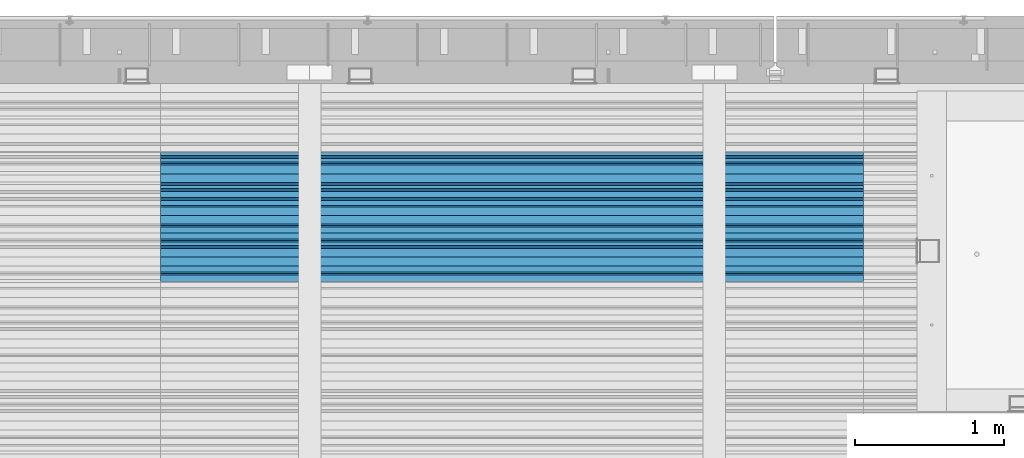
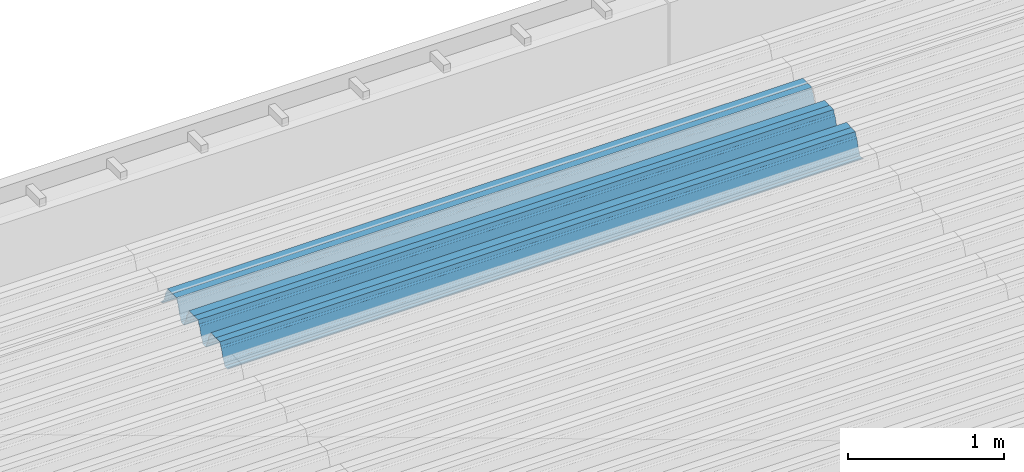
# One storey, part 34 of 153: 1 beam, 1 element without a shape of its own.
"""IFC2X3 building model written with IfcOpenShell, lengths in millimetres."""

from ifc_helpers import new_model, si_unit, frame, origin_with_axes, place, context, subcontext, project, spatial, faceted_brep, material, type_object, element, aggregate, save


model = new_model("IFC2X3")

# Units and contexts
model_context = context("Model", 3, precision=1e-05, world=origin_with_axes())
body_context = subcontext(model_context, "Body", "Model", "MODEL_VIEW")
ifc_project = project(units=[si_unit("LENGTHUNIT", "METRE", prefix="MILLI"), si_unit("AREAUNIT", "SQUARE_METRE"), si_unit("VOLUMEUNIT", "CUBIC_METRE"), si_unit("MASSUNIT", "GRAM", prefix="KILO"), si_unit("TIMEUNIT", "SECOND"), si_unit("PLANEANGLEUNIT", "RADIAN"), si_unit("SOLIDANGLEUNIT", "STERADIAN"), si_unit("THERMODYNAMICTEMPERATUREUNIT", "DEGREE_CELSIUS"), si_unit("LUMINOUSINTENSITYUNIT", "LUMEN")], contexts=[model_context])

# Site, building, storey
site_placement = place(None, origin_with_axes())
site = spatial("IfcSite", under=ifc_project, at=site_placement, CompositionType="ELEMENT")
building_placement = place(site_placement, origin_with_axes())
building = spatial("IfcBuilding", under=site, at=building_placement, CompositionType="ELEMENT")
storey_placement = place(building_placement, origin_with_axes())
storey = spatial("IfcBuildingStorey", under=building, at=storey_placement, Name="8", CompositionType="ELEMENT", Elevation=0.0)

# Assembly, beam
assembly_placement = place(storey_placement, origin_with_axes())
assembly = element("IfcElementAssembly", 1, at=assembly_placement, inside=storey, Name="Steel Assembly", AssemblyPlace="NOTDEFINED", PredefinedType="RIGID_FRAME")
ifc_material = material(Name="STEEL/S355J2")
beam_type = type_object("IfcBeamType", Name="W", PredefinedType="NOTDEFINED")
beam_placement = place(assembly_placement, frame((17251.9999999917, 19534.8848733029, 105801.771450345), z_axis=(0.0, -0.0124990270013869, 0.999921884110963), x_axis=(-1.0, 3.00000001838171e-08, 0.0)))
beam = element("IfcBeam", 2, at=beam_placement, type_object=beam_type, material=ifc_material, ObjectType="W", context=body_context, shape_type="Brep", body=[
    faceted_brep([(0.0, -412.839996337891, -77.0100021362159), (0.0, -409.160003662109, -77.0100021362014), (4717.0, -409.160003662109, -77.0100021362159), (4717.0, -412.839996337891, -77.0100021362159), (0.0, -408.070007324222, -73.4800033569045), (4717.0, -408.070007324222, -73.480003356919), (0.0, -400.339996337894, -48.0600013732619), (4717.0, -400.339996337894, -48.0600013732765), (0.0, -399.459991455082, -46.5600013732619), (4717.0, -399.459991455078, -46.5600013732765), (0.0, -390.329986572269, -36.5499992370314), (4717.0, -390.329986572266, -36.549999237046), (0.0, -389.19000244141, -34.6300010680861), (4717.0, -389.190002441403, -34.6300010681007), (0.0, -367.820007324222, 35.3400001526024), (4717.0, -367.820007324219, 35.3400001525879), (0.0, -366.989990234379, 36.8499984741502), (4717.0, -366.989990234375, 36.8499984741356), (0.0, -357.809997558597, 46.8600006103807), (4717.0, -357.809997558594, 46.8600006103661), (0.0, -356.720001220707, 48.7700004577782), (4717.0, -356.720001220703, 48.7700004577782), (0.0, -349.309997558594, 73.1500015258935), (4717.0, -349.309997558594, 73.1500015258935), (0.0, -347.850006103516, 75.2300033569481), (4717.0, -347.850006103516, 75.2300033569481), (0.0, -345.470001220707, 76.010002136245), (4717.0, -345.470001220703, 76.0100021362305), (0.0, -305.480010986332, 76.010002136245), (4717.0, -305.480010986324, 76.0100021362305), (0.0, -304.279998779301, 75.8000030517578), (4717.0, -304.279998779301, 75.8000030517724), (0.0, -291.679992675785, 71.6999969482567), (4717.0, -291.679992675785, 71.6999969482567), (0.0, -290.179992675789, 71.2300033569481), (4717.0, -290.179992675781, 71.2300033569481), (0.0, -288.720001220707, 71.6999969482567), (4717.0, -288.720001220703, 71.6999969482422), (0.0, -276.119995117191, 75.8000030517869), (4717.0, -276.119995117188, 75.8000030517724), (0.0, -274.929992675785, 76.010002136245), (4717.0, -274.929992675785, 76.010002136245), (0.0, -234.94000244141, 76.010002136245), (4717.0, -234.94000244141, 76.010002136245), (0.0, -232.550003051758, 75.2300033569627), (4717.0, -232.550003051758, 75.2300033569481), (0.0, -231.100006103519, 73.1500015258935), (4717.0, -231.100006103516, 73.1500015258789), (0.0, -223.679992675785, 48.7700004577782), (4717.0, -223.679992675781, 48.7700004577782), (0.0, -222.589996337894, 46.8600006103661), (4717.0, -222.589996337891, 46.8600006103516), (0.0, -213.410003662113, 36.8499984741502), (4717.0, -213.410003662109, 36.8499984741356), (0.0, -212.529998779301, 35.3400001526024), (4717.0, -212.529998779297, 35.3400001526024), (0.0, -191.160003662109, -34.6300010681007), (4717.0, -191.160003662109, -34.6300010681007), (0.0, -190.070007324222, -36.5499992370605), (4717.0, -190.070007324215, -36.549999237046), (0.0, -180.940002441406, -46.560001373291), (4717.0, -180.940002441406, -46.5600013732765), (0.0, -180.059997558597, -48.0600013732619), (4717.0, -180.059997558594, -48.0600013732765), (0.0, -172.330001831055, -73.480003356919), (4717.0, -172.330001831055, -73.480003356919), (0.0, -171.240005493168, -77.0100021362159), (4717.0, -171.240005493164, -77.0100021362159), (0.0, -129.330001831062, -77.0100021362014), (4717.0, -129.330001831055, -77.0100021362159), (0.0, -128.300003051761, -73.480003356919), (4717.0, -128.300003051758, -73.4800033569336), (0.0, -120.51999664307, -48.0600013732765), (4717.0, -120.519996643063, -48.0600013732765), (0.0, -119.629997253418, -46.5600013732765), (4717.0, -119.629997253418, -46.5600013732765), (0.0, -110.500000000004, -36.5499992370314), (4717.0, -110.5, -36.549999237046), (0.0, -109.419998168949, -34.6300010680861), (4717.0, -109.419998168945, -34.6300010681007), (0.0, -88.0500030517615, 35.3400001526024), (4717.0, -88.0500030517578, 35.3400001526024), (0.0, -87.160003662113, 36.8499984741356), (4717.0, -87.160003662113, 36.8499984741356), (0.0, -78.0400009155273, 46.8600006103807), (4717.0, -78.0400009155273, 46.8600006103661), (0.0, -76.8899993896557, 48.7700004577782), (4717.0, -76.8899993896521, 48.7700004577782), (0.0, -69.4800033569336, 73.1500015258935), (4717.0, -69.4800033569336, 73.1500015258935), (0.0, -68.0299987793042, 75.2300033569336), (4717.0, -68.0299987792969, 75.2300033569481), (0.0, -65.6399993896521, 76.010002136245), (4717.0, -65.6399993896484, 76.010002136245), (0.0, -25.6499996185375, 76.0100021362596), (4717.0, -25.6499996185303, 76.010002136245), (0.0, -24.5100002288891, 75.8000030517724), (4717.0, -24.5100002288818, 75.8000030517724), (0.0, -11.8500003814697, 71.6999969482567), (4717.0, -11.8500003814661, 71.6999969482567), (0.0, -10.3999996185339, 71.2300033569481), (4717.0, -10.3999996185303, 71.2300033569336), (0.0, -8.89999961853391, 71.6999969482567), (4717.0, -8.89999961853391, 71.6999969482567), (0.0, 3.71000003814333, 75.8000030517724), (4717.0, 3.71000003814697, 75.8000030517869), (0.0, 4.90000009536379, 76.0100021362596), (4717.0, 4.90000009536379, 76.010002136245), (0.0, 44.8899993896484, 76.010002136245), (4717.0, 44.8899993896484, 76.010002136245), (0.0, 47.2799987792932, 75.2300033569481), (4717.0, 47.2799987792969, 75.2300033569481), (0.0, 48.6800003051721, 73.1500015258935), (4717.0, 48.6800003051758, 73.1500015258789), (0.0, 56.1500015258753, 48.7700004577782), (4717.0, 56.1500015258789, 48.7700004577782), (0.0, 57.2400016784632, 46.8600006103807), (4717.0, 57.2400016784632, 46.8600006103661), (0.0, 66.3700027465784, 36.8499984741211), (4717.0, 66.3700027465857, 36.8499984741356), (0.0, 67.2499999999964, 35.3400001526024), (4717.0, 67.2500000000036, 35.3400001526024), (0.0, 88.6200027465748, -34.6300010681007), (4717.0, 88.620002746582, -34.6300010681152), (0.0, 89.709999084469, -36.549999237046), (4717.0, 89.7099990844727, -36.5499992370605), (0.0, 98.8899993896412, -46.5600013732765), (4717.0, 98.8899993896484, -46.5600013732765), (0.0, 99.7699966430628, -48.0600013732765), (4717.0, 99.7699966430664, -48.060001373291), (0.0, 107.499999999996, -73.4800033569336), (4717.0, 107.5, -73.480003356919), (0.0, 108.589996337887, -77.0100021362014), (4717.0, 108.589996337894, -77.0100021362159), (0.0, 112.269996643063, -77.0100021362159), (4717.0, 112.269996643066, -77.0100021362159), (0.0, 146.759994506836, -77.0100021362159), (4717.0, 146.759994506836, -77.0100021362159), (0.0, 150.440002441403, -77.0100021362159), (4717.0, 150.440002441403, -77.0100021362305), (0.0, 151.529998779297, -73.480003356919), (4717.0, 151.529998779297, -73.4800033569336), (0.0, 159.30999755859, -48.0600013732765), (4717.0, 159.309997558594, -48.0600013732765), (0.0, 160.190002441406, -46.5600013732619), (4717.0, 160.190002441406, -46.5600013732765), (0.0, 169.320007324215, -36.549999237046), (4717.0, 169.320007324222, -36.5499992370605), (0.0, 170.410003662106, -34.6300010680861), (4717.0, 170.410003662109, -34.6300010681007), (0.0, 191.779998779293, 35.3400001526024), (4717.0, 191.779998779293, 35.3400001526024), (0.0, 192.660003662109, 36.8499984741502), (4717.0, 192.660003662109, 36.8499984741356), (0.0, 201.789993286129, 46.8600006103661), (4717.0, 201.789993286133, 46.8600006103661), (0.0, 202.880004882809, 48.7700004577637), (4717.0, 202.880004882813, 48.7700004577782), (0.0, 210.350006103512, 73.150001525908), (4717.0, 210.350006103516, 73.1500015258935), (0.0, 211.800003051754, 75.2300033569481), (4717.0, 211.800003051758, 75.2300033569336), (0.0, 214.190002441406, 76.010002136245), (4717.0, 214.19000244141, 76.010002136245), (0.0, 254.179992675778, 76.010002136245), (4717.0, 254.179992675778, 76.010002136245), (0.0, 255.320007324215, 75.8000030517869), (4717.0, 255.320007324222, 75.8000030517724), (0.0, 267.980010986324, 71.6999969482713), (4717.0, 267.980010986328, 71.6999969482567), (0.0, 269.429992675778, 71.2300033569481), (4717.0, 269.429992675781, 71.2300033569481), (0.0, 270.880004882809, 71.6999969482567), (4717.0, 270.880004882813, 71.6999969482567), (0.0, 283.540008544918, 75.8000030517869), (4717.0, 283.540008544918, 75.8000030517724), (0.0, 284.679992675778, 76.010002136245), (4717.0, 284.679992675778, 76.010002136245), (0.0, 324.670013427731, 76.010002136245), (4717.0, 324.670013427738, 76.010002136245), (0.0, 327.049987792969, 75.2300033569627), (4717.0, 327.049987792969, 75.2300033569481), (0.0, 328.510009765625, 73.1500015258789), (4717.0, 328.510009765625, 73.1500015258935), (0.0, 335.980010986324, 48.7700004577782), (4717.0, 335.980010986328, 48.7700004577782), (0.0, 337.05999755859, 46.8600006103661), (4717.0, 337.059997558594, 46.8600006103516), (0.0, 346.190002441399, 36.8499984741356), (4717.0, 346.190002441406, 36.8499984741211), (0.0, 347.079986572266, 35.3400001526024), (4717.0, 347.079986572266, 35.3400001526024), (0.0, 368.450012207028, -34.6300010680861), (4717.0, 368.450012207035, -34.6300010681007), (0.0, 369.529998779293, -36.5499992370314), (4717.0, 369.529998779297, -36.549999237046), (0.0, 378.660003662106, -46.5600013732619), (4717.0, 378.660003662106, -46.5600013732765), (0.0, 379.540008544918, -48.0600013732619), (4717.0, 379.540008544922, -48.0600013732765), (0.0, 387.329986572262, -73.480003356919), (4717.0, 387.329986572266, -73.4800033569045), (0.0, 388.410003662109, -77.0100021362159), (4717.0, 388.410003662109, -77.0100021362159), (0.0, 392.100006103512, -77.0100021362159), (4717.0, 392.100006103519, -77.0100021362159), (0.0, 426.589996337887, -77.0100021362159), (4717.0, 426.589996337891, -77.0100021362159), (0.0, 430.269989013668, -77.0100021362159), (4717.0, 430.269989013672, -77.0100021362305), (0.0, 431.359985351559, -73.4800033569045), (4717.0, 431.359985351563, -73.480003356919), (0.0, 433.179992675778, -67.5699996948097), (4717.0, 433.179992675781, -67.5699996948097), (0.0, 432.220001220699, -67.2699966430373), (4717.0, 432.220001220703, -67.2699966430519), (0.0, 430.410003662106, -73.1800003051612), (4717.0, 430.410003662106, -73.1800003051758), (0.0, 429.529998779293, -76.0100021362159), (4717.0, 429.529998779293, -76.0100021362159), (0.0, 426.589996337891, -76.0100021362159), (4717.0, 426.589996337891, -76.0100021362159), (0.0, 392.100006103512, -76.0100021362159), (4717.0, 392.100006103516, -76.0100021362159), (0.0, 389.149993896481, -76.0100021362014), (4717.0, 389.149993896484, -76.0100021362159), (0.0, 388.279998779293, -73.1800003051467), (4717.0, 388.279998779301, -73.1800003051612), (0.0, 380.470001220699, -47.659999847383), (4717.0, 380.470001220703, -47.6599998473976), (0.0, 379.470001220699, -45.9599990844436), (4717.0, 379.470001220703, -45.9599990844581), (0.0, 370.350006103512, -35.9599990844581), (4717.0, 370.350006103519, -35.9599990844581), (0.0, 369.369995117184, -34.2299995422218), (4717.0, 369.369995117184, -34.2299995422218), (0.0, 347.999999999996, 35.7500000000146), (4717.0, 348.0, 35.7500000000146), (0.0, 346.999999999996, 37.4399986267235), (4717.0, 347.000000000004, 37.4399986267235), (0.0, 337.880004882809, 47.450000762954), (4717.0, 337.880004882809, 47.4500007629395), (0.0, 336.899993896481, 49.1699981689453), (4717.0, 336.899993896484, 49.1699981689599), (0.0, 329.420013427731, 73.5999984741356), (4717.0, 329.420013427734, 73.5999984741356), (0.0, 327.679992675781, 76.0699996948533), (4717.0, 327.679992675781, 76.0699996948388), (0.0, 324.829986572262, 77.010002136245), (4717.0, 324.829986572266, 77.0100021362305), (0.0, 284.589996337887, 77.010002136245), (4717.0, 284.589996337891, 77.010002136245), (0.0, 283.290008544922, 76.769996643081), (4717.0, 283.290008544922, 76.769996643081), (0.0, 270.570007324215, 72.6500015258935), (4717.0, 270.570007324219, 72.6500015258935), (0.0, 269.429992675781, 72.2799987793114), (4717.0, 269.429992675781, 72.2799987793114), (0.0, 268.279998779293, 72.650001525908), (4717.0, 268.279998779297, 72.6500015258935), (0.0, 255.570007324219, 76.769996643081), (4717.0, 255.570007324219, 76.769996643081), (0.0, 254.270004272461, 77.0100021362596), (4717.0, 254.270004272461, 77.010002136245), (0.0, 214.029998779293, 77.0100021362596), (4717.0, 214.029998779297, 77.010002136245), (0.0, 211.179992675781, 76.0699996948388), (4717.0, 211.179992675781, 76.0699996948533), (0.0, 209.440002441403, 73.5999984741356), (4717.0, 209.44000244141, 73.5999984741211), (0.0, 201.960006713864, 49.1699981689599), (4717.0, 201.960006713867, 49.1699981689453), (0.0, 200.979995727532, 47.450000762954), (4717.0, 200.979995727539, 47.4500007629395), (0.0, 191.850006103508, 37.4399986267235), (4717.0, 191.850006103516, 37.439998626709), (0.0, 190.860000610352, 35.7500000000146), (4717.0, 190.860000610352, 35.75), (0.0, 169.49000549316, -34.2299995422218), (4717.0, 169.49000549316, -34.2299995422363), (0.0, 168.509994506832, -35.9599990844581), (4717.0, 168.509994506836, -35.9599990844581), (0.0, 159.380004882805, -45.9599990844436), (4717.0, 159.380004882813, -45.9599990844581), (0.0, 158.389999389645, -47.6599998473976), (4717.0, 158.389999389645, -47.6599998474121), (0.0, 150.580001831051, -73.1800003051612), (4717.0, 150.580001831058, -73.1800003051758), (0.0, 149.710006713864, -76.0100021362159), (4717.0, 149.710006713867, -76.0100021362159), (0.0, 146.759994506836, -76.0100021362159), (4717.0, 146.759994506836, -76.0100021362159), (0.0, 112.269996643063, -76.0100021362159), (4717.0, 112.269996643063, -76.0100021362159), (0.0, 109.319999694821, -76.0100021362159), (4717.0, 109.319999694821, -76.0100021362159), (0.0, 108.449996948239, -73.1900024413917), (4717.0, 108.449996948242, -73.1900024414063), (0.0, 100.690002441406, -47.659999847383), (4717.0, 100.69000244141, -47.6599998473976), (0.0, 99.6999969482386, -45.9599990844581), (4717.0, 99.6999969482422, -45.9599990844581), (0.0, 90.5199966430664, -35.9599990844581), (4717.0, 90.5199966430664, -35.9599990844727), (0.0, 89.5400009155273, -34.2299995422218), (4717.0, 89.5400009155273, -34.2299995422218), (0.0, 68.1699981689417, 35.7500000000146), (4717.0, 68.1699981689453, 35.7500000000146), (0.0, 67.1699981689417, 37.4399986267235), (4717.0, 67.1699981689453, 37.4399986267235), (0.0, 58.0499992370569, 47.4500007629686), (4717.0, 58.0499992370605, 47.450000762954), (0.0, 57.0699996948206, 49.1699981689599), (4717.0, 57.0699996948279, 49.1699981689453), (0.0, 49.5900001525843, 73.5899963379052), (4717.0, 49.5900001525879, 73.5899963378906), (0.0, 47.9099998474085, 76.0699996948388), (4717.0, 47.9099998474121, 76.0699996948242), (0.0, 45.0499992370569, 77.010002136245), (4717.0, 45.0499992370605, 77.010002136245), (0.0, 4.82000017165774, 77.010002136245), (4717.0, 4.82000017166138, 77.010002136245), (0.0, 3.47000002860659, 76.7699966430955), (4717.0, 3.47000002860659, 76.769996643081), (0.0, -9.19999980926514, 72.6500015258935), (4717.0, -9.19999980926514, 72.6500015258789), (0.0, -10.3900003433264, 72.2799987792969), (4717.0, -10.3900003433228, 72.2799987793114), (0.0, -11.5399999618567, 72.6500015258935), (4717.0, -11.5399999618494, 72.6500015258935), (0.0, -24.2600002288855, 76.769996643081), (4717.0, -24.2600002288818, 76.769996643081), (0.0, -25.559999465946, 77.0100021362596), (4717.0, -25.5599994659424, 77.010002136245), (0.0, -65.8000030517615, 77.0100021362596), (4717.0, -65.8000030517578, 77.010002136245), (0.0, -68.6500015258862, 76.0699996948533), (4717.0, -68.6500015258825, 76.0699996948388), (0.0, -70.3899993896521, 73.5999984741356), (4717.0, -70.3899993896484, 73.5999984741211), (0.0, -77.8199996948242, 49.1800003051903), (4717.0, -77.8199996948242, 49.1800003051903), (0.0, -78.8399963378943, 47.450000762954), (4717.0, -78.8399963378906, 47.4500007629395), (0.0, -87.9700012207031, 37.4399986267235), (4717.0, -87.9700012207031, 37.4399986267235), (0.0, -88.9700012207068, 35.7500000000146), (4717.0, -88.9700012207031, 35.75), (0.0, -110.339996337894, -34.2299995422218), (4717.0, -110.339996337887, -34.2299995422218), (0.0, -111.319999694828, -35.9599990844581), (4717.0, -111.319999694824, -35.9599990844581), (0.0, -120.440002441406, -45.9599990844436), (4717.0, -120.440002441406, -45.9599990844581), (0.0, -121.44000244141, -47.6599998473976), (4717.0, -121.440002441403, -47.6599998473976), (0.0, -129.250000000004, -73.1900024413771), (4717.0, -129.25, -73.1900024413917), (0.0, -130.080001831062, -76.0100021362159), (4717.0, -130.080001831055, -76.0100021362159), (0.0, -170.5, -76.0100021362014), (4717.0, -170.5, -76.0100021362159), (0.0, -171.380004882816, -73.1900024413917), (4717.0, -171.380004882813, -73.1900024414063), (0.0, -179.139999389652, -47.6599998473976), (4717.0, -179.139999389648, -47.6599998473976), (0.0, -180.130004882816, -45.9599990844581), (4717.0, -180.130004882813, -45.9599990844581), (0.0, -189.259994506836, -35.9599990844581), (4717.0, -189.259994506832, -35.9599990844581), (0.0, -190.240005493168, -34.2299995422218), (4717.0, -190.240005493164, -34.2299995422218), (0.0, -211.610000610355, 35.7500000000146), (4717.0, -211.610000610352, 35.7500000000146), (0.0, -212.600006103519, 37.4399986267381), (4717.0, -212.600006103519, 37.4399986267235), (0.0, -221.779998779301, 47.450000762954), (4717.0, -221.779998779293, 47.4500007629395), (0.0, -222.75999450684, 49.1699981689599), (4717.0, -222.759994506836, 49.1699981689599), (0.0, -230.190002441406, 73.5999984741356), (4717.0, -230.190002441406, 73.5999984741211), (0.0, -231.919998168945, 76.0699996948388), (4717.0, -231.919998168945, 76.0699996948388), (0.0, -234.779998779301, 77.010002136245), (4717.0, -234.779998779293, 77.010002136245), (0.0, -275.010009765629, 77.010002136245), (4717.0, -275.010009765625, 77.0100021362305), (0.0, -276.359985351563, 76.769996643081), (4717.0, -276.359985351563, 76.7699966430664), (0.0, -289.029998779297, 72.6500015258789), (4717.0, -289.029998779297, 72.6500015258935), (0.0, -290.179992675785, 72.2799987793114), (4717.0, -290.179992675785, 72.2799987793114), (0.0, -291.380004882816, 72.650001525908), (4717.0, -291.380004882813, 72.6500015258935), (0.0, -304.040008544926, 76.769996643081), (4717.0, -304.040008544918, 76.769996643081), (0.0, -305.390014648441, 77.010002136245), (4717.0, -305.390014648438, 77.010002136245), (0.0, -345.63000488282, 77.0100021362596), (4717.0, -345.630004882813, 77.010002136245), (0.0, -348.480010986332, 76.0699996948388), (4717.0, -348.480010986324, 76.0699996948388), (0.0, -350.220001220707, 73.5999984741356), (4717.0, -350.220001220703, 73.5999984741211), (0.0, -357.649993896492, 49.1699981689599), (4717.0, -357.649993896484, 49.1699981689744), (0.0, -358.63000488282, 47.450000762954), (4717.0, -358.630004882813, 47.450000762954), (0.0, -367.809997558594, 37.4300003051903), (4717.0, -367.809997558594, 37.4300003051903), (0.0, -368.750000000004, 35.7299995422654), (4717.0, -368.75, 35.7299995422509), (0.0, -390.109985351566, -34.2200012207031), (4717.0, -390.109985351563, -34.2200012206886), (0.0, -391.140014648441, -35.9500007629249), (4717.0, -391.140014648438, -35.9500007629103), (0.0, -400.269989013676, -45.9599990844436), (4717.0, -400.269989013672, -45.9599990844581), (0.0, -401.269989013672, -47.6599998473976), (4717.0, -401.269989013672, -47.6599998473976), (0.0, -409.029998779297, -73.1900024413917), (4717.0, -409.029998779297, -73.1900024413917), (0.0, -409.899993896488, -76.0100021362159), (4717.0, -409.899993896481, -76.0100021362305), (0.0, -412.839996337891, -76.0100021362159), (4717.0, -412.839996337891, -76.0100021362305), (0.0, -433.179992675785, -76.0100021362159), (4717.0, -433.179992675781, -76.0100021362159), (0.0, -433.179992675785, -77.0100021362159), (4717.0, -433.179992675785, -77.0100021362305)], [[[0, 1, 2, 3]], [[1, 4, 5, 2]], [[4, 6, 7, 5]], [[6, 8, 9, 7]], [[8, 10, 11, 9]], [[10, 12, 13, 11]], [[12, 14, 15, 13]], [[14, 16, 17, 15]], [[16, 18, 19, 17]], [[18, 20, 21, 19]], [[20, 22, 23, 21]], [[22, 24, 25, 23]], [[24, 26, 27, 25]], [[26, 28, 29, 27]], [[28, 30, 31, 29]], [[30, 32, 33, 31]], [[32, 34, 35, 33]], [[34, 36, 37, 35]], [[36, 38, 39, 37]], [[38, 40, 41, 39]], [[40, 42, 43, 41]], [[42, 44, 45, 43]], [[44, 46, 47, 45]], [[46, 48, 49, 47]], [[48, 50, 51, 49]], [[50, 52, 53, 51]], [[52, 54, 55, 53]], [[54, 56, 57, 55]], [[56, 58, 59, 57]], [[58, 60, 61, 59]], [[60, 62, 63, 61]], [[62, 64, 65, 63]], [[64, 66, 67, 65]], [[66, 68, 69, 67]], [[68, 70, 71, 69]], [[70, 72, 73, 71]], [[72, 74, 75, 73]], [[74, 76, 77, 75]], [[76, 78, 79, 77]], [[78, 80, 81, 79]], [[80, 82, 83, 81]], [[82, 84, 85, 83]], [[84, 86, 87, 85]], [[86, 88, 89, 87]], [[88, 90, 91, 89]], [[90, 92, 93, 91]], [[92, 94, 95, 93]], [[94, 96, 97, 95]], [[96, 98, 99, 97]], [[98, 100, 101, 99]], [[100, 102, 103, 101]], [[102, 104, 105, 103]], [[104, 106, 107, 105]], [[106, 108, 109, 107]], [[108, 110, 111, 109]], [[110, 112, 113, 111]], [[112, 114, 115, 113]], [[114, 116, 117, 115]], [[116, 118, 119, 117]], [[118, 120, 121, 119]], [[120, 122, 123, 121]], [[122, 124, 125, 123]], [[124, 126, 127, 125]], [[126, 128, 129, 127]], [[128, 130, 131, 129]], [[130, 132, 133, 131]], [[132, 134, 135, 133]], [[134, 136, 137, 135]], [[136, 138, 139, 137]], [[138, 140, 141, 139]], [[140, 142, 143, 141]], [[142, 144, 145, 143]], [[144, 146, 147, 145]], [[146, 148, 149, 147]], [[148, 150, 151, 149]], [[150, 152, 153, 151]], [[152, 154, 155, 153]], [[154, 156, 157, 155]], [[156, 158, 159, 157]], [[158, 160, 161, 159]], [[160, 162, 163, 161]], [[162, 164, 165, 163]], [[164, 166, 167, 165]], [[166, 168, 169, 167]], [[168, 170, 171, 169]], [[170, 172, 173, 171]], [[172, 174, 175, 173]], [[174, 176, 177, 175]], [[176, 178, 179, 177]], [[178, 180, 181, 179]], [[180, 182, 183, 181]], [[182, 184, 185, 183]], [[184, 186, 187, 185]], [[186, 188, 189, 187]], [[188, 190, 191, 189]], [[190, 192, 193, 191]], [[192, 194, 195, 193]], [[194, 196, 197, 195]], [[196, 198, 199, 197]], [[198, 200, 201, 199]], [[200, 202, 203, 201]], [[202, 204, 205, 203]], [[204, 206, 207, 205]], [[206, 208, 209, 207]], [[208, 210, 211, 209]], [[210, 212, 213, 211]], [[212, 214, 215, 213]], [[214, 216, 217, 215]], [[216, 218, 219, 217]], [[218, 220, 221, 219]], [[220, 222, 223, 221]], [[222, 224, 225, 223]], [[224, 226, 227, 225]], [[226, 228, 229, 227]], [[228, 230, 231, 229]], [[230, 232, 233, 231]], [[232, 234, 235, 233]], [[234, 236, 237, 235]], [[236, 238, 239, 237]], [[238, 240, 241, 239]], [[240, 242, 243, 241]], [[242, 244, 245, 243]], [[244, 246, 247, 245]], [[246, 248, 249, 247]], [[248, 250, 251, 249]], [[250, 252, 253, 251]], [[252, 254, 255, 253]], [[254, 256, 257, 255]], [[256, 258, 259, 257]], [[258, 260, 261, 259]], [[260, 262, 263, 261]], [[262, 264, 265, 263]], [[264, 266, 267, 265]], [[266, 268, 269, 267]], [[268, 270, 271, 269]], [[270, 272, 273, 271]], [[272, 274, 275, 273]], [[274, 276, 277, 275]], [[276, 278, 279, 277]], [[278, 280, 281, 279]], [[280, 282, 283, 281]], [[282, 284, 285, 283]], [[284, 286, 287, 285]], [[286, 288, 289, 287]], [[288, 290, 291, 289]], [[290, 292, 293, 291]], [[292, 294, 295, 293]], [[294, 296, 297, 295]], [[296, 298, 299, 297]], [[298, 300, 301, 299]], [[300, 302, 303, 301]], [[302, 304, 305, 303]], [[304, 306, 307, 305]], [[306, 308, 309, 307]], [[308, 310, 311, 309]], [[310, 312, 313, 311]], [[312, 314, 315, 313]], [[314, 316, 317, 315]], [[316, 318, 319, 317]], [[318, 320, 321, 319]], [[320, 322, 323, 321]], [[322, 324, 325, 323]], [[324, 326, 327, 325]], [[326, 328, 329, 327]], [[328, 330, 331, 329]], [[330, 332, 333, 331]], [[332, 334, 335, 333]], [[334, 336, 337, 335]], [[336, 338, 339, 337]], [[338, 340, 341, 339]], [[340, 342, 343, 341]], [[342, 344, 345, 343]], [[344, 346, 347, 345]], [[346, 348, 349, 347]], [[348, 350, 351, 349]], [[350, 352, 353, 351]], [[352, 354, 355, 353]], [[354, 356, 357, 355]], [[356, 358, 359, 357]], [[358, 360, 361, 359]], [[360, 362, 363, 361]], [[362, 364, 365, 363]], [[364, 366, 367, 365]], [[366, 368, 369, 367]], [[368, 370, 371, 369]], [[370, 372, 373, 371]], [[372, 374, 375, 373]], [[374, 376, 377, 375]], [[376, 378, 379, 377]], [[378, 380, 381, 379]], [[380, 382, 383, 381]], [[382, 384, 385, 383]], [[384, 386, 387, 385]], [[386, 388, 389, 387]], [[388, 390, 391, 389]], [[390, 392, 393, 391]], [[392, 394, 395, 393]], [[394, 396, 397, 395]], [[396, 398, 399, 397]], [[398, 400, 401, 399]], [[400, 402, 403, 401]], [[402, 404, 405, 403]], [[404, 406, 407, 405]], [[406, 408, 409, 407]], [[408, 410, 411, 409]], [[410, 412, 413, 411]], [[412, 414, 415, 413]], [[414, 416, 417, 415]], [[416, 418, 419, 417]], [[418, 420, 421, 419]], [[420, 422, 423, 421]], [[422, 424, 425, 423]], [[424, 426, 427, 425]], [[426, 428, 429, 427]], [[428, 430, 431, 429]], [[430, 0, 3, 431]], [[5, 7, 9, 11, 13, 15, 17, 19, 21, 23, 25, 27, 29, 31, 33, 35, 37, 39, 41, 43, 45, 47, 49, 51, 53, 55, 57, 59, 61, 63, 65, 67, 69, 71, 73, 75, 77, 79, 81, 83, 85, 87, 89, 91, 93, 95, 97, 99, 101, 103, 105, 107, 109, 111, 113, 115, 117, 119, 121, 123, 125, 127, 129, 131, 133, 135, 137, 139, 141, 143, 145, 147, 149, 151, 153, 155, 157, 159, 161, 163, 165, 167, 169, 171, 173, 175, 177, 179, 181, 183, 185, 187, 189, 191, 193, 195, 197, 199, 201, 203, 205, 207, 209, 211, 213, 215, 217, 219, 221, 223, 225, 227, 229, 231, 233, 235, 237, 239, 241, 243, 245, 247, 249, 251, 253, 255, 257, 259, 261, 263, 265, 267, 269, 271, 273, 275, 277, 279, 281, 283, 285, 287, 289, 291, 293, 295, 297, 299, 301, 303, 305, 307, 309, 311, 313, 315, 317, 319, 321, 323, 325, 327, 329, 331, 333, 335, 337, 339, 341, 343, 345, 347, 349, 351, 353, 355, 357, 359, 361, 363, 365, 367, 369, 371, 373, 375, 377, 379, 381, 383, 385, 387, 389, 391, 393, 395, 397, 399, 401, 403, 405, 407, 409, 411, 413, 415, 417, 419, 421, 423, 425, 427, 429, 431, 3, 2]], [[430, 428, 426, 424, 422, 420, 418, 416, 414, 412, 410, 408, 406, 404, 402, 400, 398, 396, 394, 392, 390, 388, 386, 384, 382, 380, 378, 376, 374, 372, 370, 368, 366, 364, 362, 360, 358, 356, 354, 352, 350, 348, 346, 344, 342, 340, 338, 336, 334, 332, 330, 328, 326, 324, 322, 320, 318, 316, 314, 312, 310, 308, 306, 304, 302, 300, 298, 296, 294, 292, 290, 288, 286, 284, 282, 280, 278, 276, 274, 272, 270, 268, 266, 264, 262, 260, 258, 256, 254, 252, 250, 248, 246, 244, 242, 240, 238, 236, 234, 232, 230, 228, 226, 224, 222, 220, 218, 216, 214, 212, 210, 208, 206, 204, 202, 200, 198, 196, 194, 192, 190, 188, 186, 184, 182, 180, 178, 176, 174, 172, 170, 168, 166, 164, 162, 160, 158, 156, 154, 152, 150, 148, 146, 144, 142, 140, 138, 136, 134, 132, 130, 128, 126, 124, 122, 120, 118, 116, 114, 112, 110, 108, 106, 104, 102, 100, 98, 96, 94, 92, 90, 88, 86, 84, 82, 80, 78, 76, 74, 72, 70, 68, 66, 64, 62, 60, 58, 56, 54, 52, 50, 48, 46, 44, 42, 40, 38, 36, 34, 32, 30, 28, 26, 24, 22, 20, 18, 16, 14, 12, 10, 8, 6, 4, 1, 0]]]),
])
aggregate(assembly, [beam])

save(model, "model.ifc")
